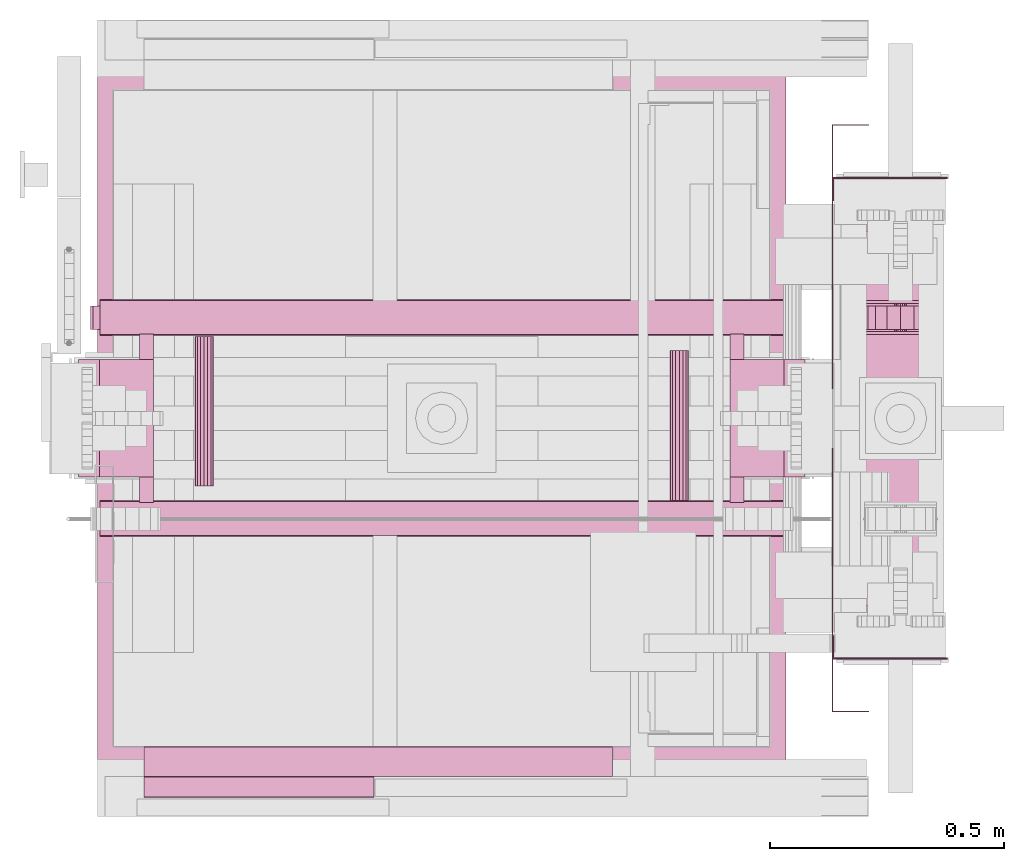
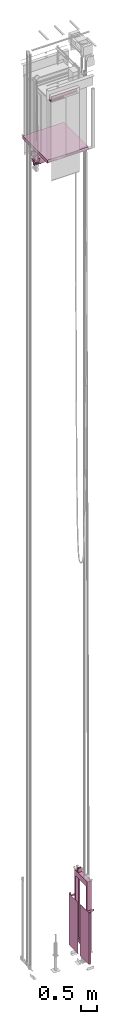
# One storey, part 5 of 13: 6 transport elements.
"""IFC4 building model written with IfcOpenShell, lengths in millimetres."""

import ifcopenshell
import ifcopenshell.guid

model = None  # the IFC model being written
_history = None  # IfcOwnerHistory: only IFC2X3 demands one
_inside = {}  # id of a spatial element -> (the spatial element, [elements in it])
_under = {}  # id of a project, library or spatial element -> (it, [spatial elements below it])
_declared = {}  # id of a project -> (the project, [libraries it declares])
_typed = {}  # id of a type object -> (the type object, [elements of that type])
_made_of = {}  # id of a material, layer set ... -> (it, [elements and type objects made of it])


def new_model(schema):
    """Start an empty IFC model of exactly this schema.

    Asked for "IFC4X3", IfcOpenShell would pick the latest addendum, in which some entities
    have other attributes; the version numbers below select the first issue.
    IFC2X3 requires an IfcOwnerHistory on every rooted entity: one is made here for all.
    """
    global model, _history
    if schema == "IFC4X3":
        model = ifcopenshell.file(schema_version=(4, 3, 0, 0))
    else:
        model = ifcopenshell.file(schema=schema)
    _inside.clear()
    _under.clear()
    _declared.clear()
    _typed.clear()
    _made_of.clear()
    _history = None
    if model.schema == "IFC2X3":
        org = make("IfcOrganization", Name="unknown")
        user = make(
            "IfcPersonAndOrganization",
            ThePerson=make("IfcPerson", FamilyName="unknown"),
            TheOrganization=org,
        )
        app = make(
            "IfcApplication",
            ApplicationDeveloper=org,
            Version="unknown",
            ApplicationFullName="unknown",
            ApplicationIdentifier="unknown",
        )
        _history = make(
            "IfcOwnerHistory",
            OwningUser=user,
            OwningApplication=app,
            ChangeAction="ADDED",
            CreationDate=0,
        )
    return model


def make(cls, **values):
    """One entity of the class cls with the attributes given. An attribute that is None is left unset."""
    return model.create_entity(
        cls, **{name: value for name, value in values.items() if value is not None}
    )


def entity(cls, *values):
    """Any entity or typed value of the class cls, its attributes in the order of the schema. None: left unset."""
    e = model.create_entity(cls)
    for i, value in enumerate(values):
        if value is not None:
            e[i] = value
    return e


def rooted(cls, **values):
    """An entity with a GlobalId (a new one), such as an element, a storey or a relation."""
    return make(cls, GlobalId=ifcopenshell.guid.new(), OwnerHistory=_history, **values)


def si_unit(unit_type, name, prefix=None):
    """IfcSIUnit, for example si_unit("LENGTHUNIT", "METRE", prefix="MILLI")."""
    return make("IfcSIUnit", UnitType=unit_type, Prefix=prefix, Name=name)


def converted_unit(unit_type, name, factor, base, dimensions=None, offset=None):
    """IfcConversionBasedUnit, such as the inch: factor (a typed value) times the base unit."""
    return make(
        "IfcConversionBasedUnit"
        if offset is None
        else "IfcConversionBasedUnitWithOffset",
        ConversionOffset=offset,
        Dimensions=None
        if dimensions is None
        else entity("IfcDimensionalExponents", *dimensions),
        UnitType=unit_type,
        Name=name,
        ConversionFactor=make(
            "IfcMeasureWithUnit", ValueComponent=factor, UnitComponent=base
        ),
    )


def assignment(units):
    """IfcUnitAssignment: the units of a project."""
    return None if units is None else make("IfcUnitAssignment", Units=units)


def point(xyz):
    """IfcCartesianPoint."""
    return None if xyz is None else make("IfcCartesianPoint", Coordinates=xyz)


def direction(xyz):
    """IfcDirection."""
    return None if xyz is None else make("IfcDirection", DirectionRatios=xyz)


def frame(location, z_axis=None, x_axis=None):
    """IfcAxis2Placement3D, a coordinate frame: its origin and axes. An axis left out is left unset."""
    return make(
        "IfcAxis2Placement3D",
        Location=point(location),
        Axis=direction(z_axis),
        RefDirection=direction(x_axis),
    )


def origin_with_axes():
    """The frame at (0, 0, 0) with the z axis (0, 0, 1) and the x axis (1, 0, 0) written out."""
    return frame((0.0, 0.0, 0.0), z_axis=(0.0, 0.0, 1.0), x_axis=(1.0, 0.0, 0.0))


def place(relative_to, where):
    """IfcLocalPlacement: puts the frame where relative to a parent placement (None: the world)."""
    return make(
        "IfcLocalPlacement", PlacementRelTo=relative_to, RelativePlacement=where
    )


def context(
    kind, dimensions, precision=None, world=None, true_north=None, identifier=None
):
    """IfcGeometricRepresentationContext, for example the 3D "Model" context."""
    return make(
        "IfcGeometricRepresentationContext",
        ContextIdentifier=identifier,
        ContextType=kind,
        CoordinateSpaceDimension=dimensions,
        Precision=precision,
        WorldCoordinateSystem=world,
        TrueNorth=true_north,
    )


def subcontext(parent, identifier, kind, view, scale=None):
    """IfcGeometricRepresentationSubContext, for example "Body" below "Model"."""
    return make(
        "IfcGeometricRepresentationSubContext",
        ContextIdentifier=identifier,
        ContextType=kind,
        ParentContext=parent,
        TargetScale=scale,
        TargetView=view,
    )


def project(units=None, contexts=None):
    """IfcProject with its units and contexts."""
    return rooted(
        "IfcProject",
        Name="project",
        RepresentationContexts=contexts,
        UnitsInContext=assignment(units),
    )


def spatial(cls, under=None, at=None, **own):
    """A site, building, storey or space (cls), placed at a placement, below another one or the project."""
    s = rooted(cls, ObjectPlacement=at, **own)
    if under is not None:
        _under.setdefault(under.id(), (under, []))[1].append(s)
    return s


def faces_of(points, faces, orient=None, outer=None):
    """IfcFace entities. A face is a list of loops; a loop is a list of indices into points, from 0.

    orient and outer hold one flag for each loop. By default every Orientation is true, the
    first loop of a face is its IfcFaceOuterBound and the others are IfcFaceBound.
    """
    made = []
    for i, loops in enumerate(faces):
        bounds = []
        for j, loop in enumerate(loops):
            is_outer = j == 0 if outer is None else outer[i][j]
            bounds.append(
                make(
                    "IfcFaceOuterBound" if is_outer else "IfcFaceBound",
                    Bound=make("IfcPolyLoop", Polygon=[points[k] for k in loop]),
                    Orientation=True if orient is None else orient[i][j],
                )
            )
        made.append(make("IfcFace", Bounds=bounds))
    return made


def faceted_brep(points, faces, orient=None, outer=None, voids=None):
    """IfcFacetedBrep: a solid bounded by flat faces; with voids (closed shells), ...WithVoids."""
    shared = [point(p) for p in points]
    hull = make("IfcClosedShell", CfsFaces=faces_of(shared, faces, orient, outer))
    if voids is None:
        return make("IfcFacetedBrep", Outer=hull)
    return make(
        "IfcFacetedBrepWithVoids",
        Outer=hull,
        Voids=[
            make(cls, CfsFaces=faces_of(shared, fs, o, b)) for cls, fs, o, b in voids
        ],
    )


def shape(context_of_items, identifier, shape_type, items):
    """IfcShapeRepresentation: the items that make up one representation, for example the "Body"."""
    return make(
        "IfcShapeRepresentation",
        ContextOfItems=context_of_items,
        RepresentationIdentifier=identifier,
        RepresentationType=shape_type,
        Items=items,
    )


def made_of(thing, what):
    """Note that an element or type object is made of a material, layer set ...; save() writes the relation."""
    if what is not None:
        _made_of.setdefault(what.id(), (what, []))[1].append(thing)
    return thing


def element(
    cls,
    number,
    at=None,
    inside=None,
    cuts=None,
    type_object=None,
    material=None,
    context=None,
    identifier="Body",
    shape_type=None,
    held_by="IfcProductDefinitionShape",
    body=None,
    shapes=None,
    **own,
):
    """One element of the class cls, such as IfcWall. Its Tag is "e" and its number.

    at: its placement. inside: the storey or other place that contains it. cuts: it is an
    opening in that element (IfcRelVoidsElement). A single representation is given by context,
    identifier, shape_type and body (its items); several are given by shapes. held_by: the class
    of the entity that holds the representations. save() writes the other relations.
    """
    e = rooted(cls, Tag="e%d" % number, ObjectPlacement=at, **own)
    if body is not None:
        shapes = [shape(context, identifier, shape_type, body)]
    if shapes is not None:
        e.Representation = make(held_by, Representations=shapes)
    if inside is not None:
        _inside.setdefault(inside.id(), (inside, []))[1].append(e)
    if cuts is not None:
        rooted(
            "IfcRelVoidsElement", RelatingBuildingElement=cuts, RelatedOpeningElement=e
        )
    if type_object is not None:
        _typed.setdefault(type_object.id(), (type_object, []))[1].append(e)
    return made_of(e, material)


def aggregate(whole, parts):
    """IfcRelAggregates: a whole, such as a stair, and the parts it consists of."""
    return rooted("IfcRelAggregates", RelatingObject=whole, RelatedObjects=parts)


def save(model, path):
    """Write the relations noted so far, then the file.

    IfcRelAggregates (storeys below a building ...), IfcRelContainedInSpatialStructure (elements
    in a storey), IfcRelDefinesByType, IfcRelAssociatesMaterial and IfcRelDeclares: one each for
    every whole, place, type object, material and project.
    """
    for whole, parts in _under.values():
        aggregate(whole, parts)
    for where, things in _inside.values():
        rooted(
            "IfcRelContainedInSpatialStructure",
            RelatedElements=things,
            RelatingStructure=where,
        )
    for kind, things in _typed.values():
        rooted("IfcRelDefinesByType", RelatedObjects=things, RelatingType=kind)
    for what, things in _made_of.values():
        rooted("IfcRelAssociatesMaterial", RelatedObjects=things, RelatingMaterial=what)
    for by, libraries in _declared.values():
        rooted("IfcRelDeclares", RelatingContext=by, RelatedDefinitions=libraries)
    model.write(path)


model = new_model("IFC4")

# Units and contexts
context_of_model = context(None, 3, precision=0.01, world=origin_with_axes())
sub_context_1 = subcontext(context_of_model, None, None, "MODEL_VIEW")
sub_context_2 = subcontext(context_of_model, None, None, "MODEL_VIEW")
sub_context_3 = subcontext(context_of_model, None, None, "MODEL_VIEW")
sub_context_4 = subcontext(context_of_model, None, None, "MODEL_VIEW")
sub_context_5 = subcontext(context_of_model, None, None, "MODEL_VIEW")
sub_context_6 = subcontext(context_of_model, None, None, "MODEL_VIEW")
ifc_project = project(units=[converted_unit("PLANEANGLEUNIT", "degree", entity("IfcPlaneAngleMeasure", 0.017453292519943), si_unit("PLANEANGLEUNIT", "RADIAN"), dimensions=[0, 0, 0, 0, 0, 0, 0]), si_unit("LENGTHUNIT", "METRE", prefix="MILLI"), si_unit("MASSUNIT", "GRAM", prefix="KILO"), converted_unit("TIMEUNIT", "year", entity("IfcTimeMeasure", 31557600.0), si_unit("TIMEUNIT", "SECOND"), dimensions=[0, 0, 1, 0, 0, 0, 0]), si_unit("THERMODYNAMICTEMPERATUREUNIT", "DEGREE_CELSIUS"), si_unit("AREAUNIT", "SQUARE_METRE"), si_unit("FORCEUNIT", "NEWTON"), si_unit("VOLUMEUNIT", "CUBIC_METRE"), si_unit("PRESSUREUNIT", "PASCAL"), si_unit("SOLIDANGLEUNIT", "STERADIAN")], contexts=[context_of_model])

# Site, building, storey
site = spatial("IfcSite", under=ifc_project)
building = spatial("IfcBuilding", under=site, Name="Document")
placement = place(None, origin_with_axes())
storey_placement = place(placement, frame((0.0, 0.0, -26400.0), z_axis=(0.0, 0.0, 1.0), x_axis=(1.0, 0.0, 0.0)))
storey = spatial("IfcBuildingStorey", under=building, at=storey_placement, Name="Z -26400", Elevation=-26400.0)

# Transport elements
transport_element_1_placement = place(storey_placement, frame((1734.0, 1025.0, 0.0), z_axis=(0.0, 0.0, 1.0), x_axis=(0.0, 1.0, 0.0)))
element("IfcTransportElement", 1, at=transport_element_1_placement, inside=storey, ObjectType="GGM3 Screen CMG", PredefinedType="ELEVATOR", context=sub_context_1, shape_type="Brep", body=[
    faceted_brep([(-626.0, 1.0, 2245.0), (-63.5, 1.0, 2245.0), (-63.5, 1.0, 300.0), (-626.0, 1.0, 300.0), (-63.5, 0.0, 300.0), (-63.5, 0.0, 2245.0), (-625.0, 0.0, 2245.0), (-625.0, 0.0, 300.0), (-625.0, -77.0, 300.0), (-625.0, -77.0, 2245.0), (-626.0, -77.0, 2245.0), (-626.0, -77.0, 300.0)], [[[0, 1, 2, 3]], [[4, 5, 6, 7]], [[8, 9, 10, 11]], [[11, 10, 0, 3]], [[6, 9, 8, 7]], [[1, 5, 4, 2]], [[3, 2, 4, 7, 8, 11]], [[10, 9, 6, 5, 1, 0]]]),
    faceted_brep([(63.5, 1.0, 2245.0), (626.0, 1.0, 2245.0), (626.0, 1.0, 300.0), (63.5, 1.0, 300.0), (625.0, 0.0, 300.0), (625.0, 0.0, 2245.0), (63.5, 0.0, 2245.0), (63.5, 0.0, 300.0), (626.0, -77.0, 300.0), (626.0, -77.0, 2245.0), (625.0, -77.0, 2245.0), (625.0, -77.0, 300.0)], [[[0, 1, 2, 3]], [[4, 5, 6, 7]], [[8, 9, 10, 11]], [[7, 6, 0, 3]], [[1, 9, 8, 2]], [[11, 10, 5, 4]], [[2, 8, 11, 4, 7, 3]], [[6, 5, 10, 9, 1, 0]]]),
    faceted_brep([(464.0, 0.0, 2245.0), (514.0, 0.0, 2245.0), (514.0, 0.0, 2170.0), (464.0, 0.0, 2170.0), (511.0, -3.0, 2170.0), (511.0, -3.0, 2245.0), (464.0, -3.0, 2245.0), (464.0, -3.0, 2170.0), (514.0, -245.0, 2170.0), (514.0, -245.0, 2245.0), (511.0, -245.0, 2245.0), (511.0, -245.0, 2170.0)], [[[0, 1, 2, 3]], [[4, 5, 6, 7]], [[8, 9, 10, 11]], [[7, 6, 0, 3]], [[1, 9, 8, 2]], [[11, 10, 5, 4]], [[2, 8, 11, 4, 7, 3]], [[6, 5, 10, 9, 1, 0]]]),
    faceted_brep([(-514.0, 0.0, 2245.0), (-464.0, 0.0, 2245.0), (-464.0, 0.0, 2170.0), (-514.0, 0.0, 2170.0), (-464.0, -3.0, 2170.0), (-464.0, -3.0, 2245.0), (-511.0, -3.0, 2245.0), (-511.0, -3.0, 2170.0), (-511.0, -245.0, 2170.0), (-511.0, -245.0, 2245.0), (-514.0, -245.0, 2245.0), (-514.0, -245.0, 2170.0)], [[[0, 1, 2, 3]], [[4, 5, 6, 7]], [[8, 9, 10, 11]], [[11, 10, 0, 3]], [[6, 9, 8, 7]], [[1, 5, 4, 2]], [[3, 2, 4, 7, 8, 11]], [[10, 9, 6, 5, 1, 0]]]),
])
transport_element_2_placement = place(storey_placement, frame((1879.0, 1025.0, 489.0), z_axis=(0.0, 0.0, 1.0), x_axis=(0.0, 1.0, 0.0)))
element("IfcTransportElement", 2, at=transport_element_2_placement, inside=storey, ObjectType="S5500 GGM3 right/rear", PredefinedType="ELEVATOR", context=sub_context_2, shape_type="Brep", body=[
    faceted_brep([(245.0, 12.5, 2840.0), (245.0, 11.5484619140625, 2844.783447265625), (245.0, 8.8388671875, 2848.8388671875), (245.0, 4.7835693359375, 2851.548583984375), (245.0, 0.0, 2852.5), (245.0, -4.7835693359375, 2851.548583984375), (245.0, -8.8388671875, 2848.8388671875), (245.0, -11.5484619140625, 2844.783447265625), (245.0, -12.5, 2840.0), (245.0, -11.5484619140625, 2835.216552734375), (245.0, -8.8388671875, 2831.1611328125), (245.0, -4.7835693359375, 2828.451416015625), (245.0, 0.0, 2827.5), (245.0, 4.7835693359375, 2828.451416015625), (245.0, 8.8388671875, 2831.1611328125), (245.0, 11.5484619140625, 2835.216552734375), (185.0, 12.5, 2840.0), (185.0, 11.5484619140625, 2835.216552734375), (185.0, 8.8388671875, 2831.1611328125), (185.0, 4.7835693359375, 2828.451416015625), (185.0, 0.0, 2827.5), (185.0, -4.7835693359375, 2828.451416015625), (185.0, -8.8388671875, 2831.1611328125), (185.0, -11.5484619140625, 2835.216552734375), (185.0, -12.5, 2840.0), (185.0, -11.5484619140625, 2844.783447265625), (185.0, -8.8388671875, 2848.8388671875), (185.0, -4.7835693359375, 2851.548583984375), (185.0, 0.0, 2852.5), (185.0, 4.7835693359375, 2851.548583984375), (185.0, 8.8388671875, 2848.8388671875), (185.0, 11.5484619140625, 2844.783447265625)], [[[0, 1, 2, 3, 4, 5, 6, 7, 8, 9, 10, 11, 12, 13, 14, 15]], [[16, 17, 18, 19, 20, 21, 22, 23, 24, 25, 26, 27, 28, 29, 30, 31]], [[0, 15, 17, 16]], [[15, 14, 18, 17]], [[14, 13, 19, 18]], [[13, 12, 20, 19]], [[12, 11, 21, 20]], [[11, 10, 22, 21]], [[10, 9, 23, 22]], [[9, 8, 24, 23]], [[8, 7, 25, 24]], [[7, 6, 26, 25]], [[6, 5, 27, 26]], [[5, 4, 28, 27]], [[4, 3, 29, 28]], [[3, 2, 30, 29]], [[2, 1, 31, 30]], [[1, 0, 16, 31]]]),
    faceted_brep([(179.0, 77.0, 2760.0), (179.0, 77.0, 2910.0), (185.0, 77.0, 2910.0), (185.0, 77.0, 2766.0), (245.0, 77.0, 2766.0), (245.0, 77.0, 2910.0), (251.0, 77.0, 2910.0), (251.0, 77.0, 2760.0), (251.0, -77.0, 2760.0), (251.0, -77.0, 2910.0), (245.0, -77.0, 2910.0), (245.0, -77.0, 2766.0), (185.0, -77.0, 2766.0), (185.0, -77.0, 2910.0), (179.0, -77.0, 2910.0), (179.0, -77.0, 2760.0)], [[[0, 1, 2, 3, 4, 5, 6, 7]], [[8, 9, 10, 11, 12, 13, 14, 15]], [[15, 14, 1, 0]], [[2, 13, 12, 3]], [[11, 10, 5, 4]], [[6, 9, 8, 7]], [[7, 8, 15, 0]], [[12, 11, 4, 3]], [[14, 13, 2, 1]], [[10, 9, 6, 5]]]),
    faceted_brep([(-400.0, 80.0, 2760.0), (-330.0, 80.0, 2760.0), (-330.0, 80.0, 160.0), (-400.0, 80.0, 160.0), (-330.0, 77.0, 160.0), (-330.0, 77.0, 2760.0), (-397.0, 77.0, 2760.0), (-397.0, 77.0, 160.0), (-397.0, -77.0, 2760.0), (-330.0, -77.0, 2760.0), (-330.0, -77.0, 160.0), (-397.0, -77.0, 160.0), (-330.0, -80.0, 160.0), (-330.0, -80.0, 2760.0), (-400.0, -80.0, 2760.0), (-400.0, -80.0, 160.0)], [[[0, 1, 2, 3]], [[4, 5, 6, 7]], [[8, 9, 10, 11]], [[12, 13, 14, 15]], [[15, 14, 0, 3]], [[6, 8, 11, 7]], [[1, 5, 4, 2]], [[9, 13, 12, 10]], [[2, 4, 7, 11, 10, 12, 15, 3]], [[0, 14, 13, 9, 8, 6, 5, 1]]]),
    faceted_brep([(240.0, 75.0, 2840.0), (240.0, 69.291015625, 2868.701171875), (240.0, 53.032958984375, 2893.032958984375), (240.0, 28.7012939453125, 2909.291015625), (240.0, 0.0, 2915.0), (240.0, -28.7012939453125, 2909.291015625), (240.0, -53.032958984375, 2893.032958984375), (240.0, -69.291015625, 2868.701171875), (240.0, -75.0, 2840.0), (240.0, -69.291015625, 2811.298828125), (240.0, -53.032958984375, 2786.967041015625), (240.0, -28.7012939453125, 2770.708984375), (240.0, 0.0, 2765.0), (240.0, 28.7012939453125, 2770.708984375), (240.0, 53.032958984375, 2786.967041015625), (240.0, 69.291015625, 2811.298828125), (190.0, 75.0, 2840.0), (190.0, 69.291015625, 2811.298828125), (190.0, 53.032958984375, 2786.967041015625), (190.0, 28.7012939453125, 2770.708984375), (190.0, 0.0, 2765.0), (190.0, -28.7012939453125, 2770.708984375), (190.0, -53.032958984375, 2786.967041015625), (190.0, -69.291015625, 2811.298828125), (190.0, -75.0, 2840.0), (190.0, -69.291015625, 2868.701171875), (190.0, -53.032958984375, 2893.032958984375), (190.0, -28.7012939453125, 2909.291015625), (190.0, 0.0, 2915.0), (190.0, 28.7012939453125, 2909.291015625), (190.0, 53.032958984375, 2893.032958984375), (190.0, 69.291015625, 2868.701171875)], [[[0, 1, 2, 3, 4, 5, 6, 7, 8, 9, 10, 11, 12, 13, 14, 15]], [[16, 17, 18, 19, 20, 21, 22, 23, 24, 25, 26, 27, 28, 29, 30, 31]], [[0, 15, 17, 16]], [[15, 14, 18, 17]], [[14, 13, 19, 18]], [[13, 12, 20, 19]], [[12, 11, 21, 20]], [[11, 10, 22, 21]], [[10, 9, 23, 22]], [[9, 8, 24, 23]], [[8, 7, 25, 24]], [[7, 6, 26, 25]], [[6, 5, 27, 26]], [[5, 4, 28, 27]], [[4, 3, 29, 28]], [[3, 2, 30, 29]], [[2, 1, 31, 30]], [[1, 0, 16, 31]]]),
    faceted_brep([(-70.0, 70.0, 150.0), (-70.0, 70.0, 0.0), (-70.0, -70.0, 0.0), (-70.0, -70.0, 150.0), (70.0, 70.0, 150.0), (70.0, -70.0, 150.0), (70.0, -70.0, 0.0), (70.0, 70.0, 0.0)], [[[0, 1, 2, 3]], [[4, 5, 6, 7]], [[0, 3, 5, 4]], [[3, 2, 6, 5]], [[2, 1, 7, 6]], [[1, 0, 4, 7]]]),
    faceted_brep([(-397.0, 77.0, 2760.0), (397.0, 77.0, 2760.0), (397.0, 77.0, 2560.0), (-397.0, 77.0, 2560.0), (397.0, 71.0, 2560.0), (397.0, 71.0, 2754.0), (-397.0, 71.0, 2754.0), (-397.0, 71.0, 2560.0), (-397.0, -71.0, 2754.0), (397.0, -71.0, 2754.0), (397.0, -71.0, 2560.0), (-397.0, -71.0, 2560.0), (397.0, -77.0, 2560.0), (397.0, -77.0, 2760.0), (-397.0, -77.0, 2760.0), (-397.0, -77.0, 2560.0)], [[[0, 1, 2, 3]], [[4, 5, 6, 7]], [[8, 9, 10, 11]], [[12, 13, 14, 15]], [[7, 6, 8, 11, 15, 14, 0, 3]], [[1, 13, 12, 10, 9, 5, 4, 2]], [[2, 4, 7, 3]], [[14, 13, 1, 0]], [[5, 9, 8, 6]], [[10, 12, 15, 11]]]),
    faceted_brep([(-397.0, 77.0, 310.0), (397.0, 77.0, 310.0), (397.0, 77.0, 160.0), (-397.0, 77.0, 160.0), (397.0, 71.0, 166.0), (397.0, 71.0, 310.0), (-397.0, 71.0, 310.0), (-397.0, 71.0, 166.0), (-397.0, -71.0, 310.0), (397.0, -71.0, 310.0), (397.0, -71.0, 166.0), (-397.0, -71.0, 166.0), (397.0, -77.0, 160.0), (397.0, -77.0, 310.0), (-397.0, -77.0, 310.0), (-397.0, -77.0, 160.0)], [[[0, 1, 2, 3]], [[4, 5, 6, 7]], [[8, 9, 10, 11]], [[12, 13, 14, 15]], [[3, 15, 14, 8, 11, 7, 6, 0]], [[1, 5, 4, 10, 9, 13, 12, 2]], [[2, 12, 15, 3]], [[11, 10, 4, 7]], [[6, 5, 1, 0]], [[14, 13, 9, 8]]]),
    faceted_brep([(330.0, 80.0, 2760.0), (400.0, 80.0, 2760.0), (400.0, 80.0, 160.0), (330.0, 80.0, 160.0), (397.0, 77.0, 160.0), (397.0, 77.0, 2760.0), (330.0, 77.0, 2760.0), (330.0, 77.0, 160.0), (330.0, -77.0, 2760.0), (397.0, -77.0, 2760.0), (397.0, -77.0, 160.0), (330.0, -77.0, 160.0), (400.0, -80.0, 160.0), (400.0, -80.0, 2760.0), (330.0, -80.0, 2760.0), (330.0, -80.0, 160.0)], [[[0, 1, 2, 3]], [[4, 5, 6, 7]], [[8, 9, 10, 11]], [[12, 13, 14, 15]], [[7, 6, 0, 3]], [[1, 13, 12, 2]], [[10, 9, 5, 4]], [[15, 14, 8, 11]], [[2, 12, 15, 11, 10, 4, 7, 3]], [[6, 5, 9, 8, 14, 13, 1, 0]]]),
    faceted_brep([(-75.0, 80.0, 160.0), (-75.0, 80.0, 150.0), (-75.0, -80.0, 150.0), (-75.0, -80.0, 160.0), (75.0, 80.0, 160.0), (75.0, -80.0, 160.0), (75.0, -80.0, 150.0), (75.0, 80.0, 150.0)], [[[0, 1, 2, 3]], [[4, 5, 6, 7]], [[0, 3, 5, 4]], [[3, 2, 6, 5]], [[2, 1, 7, 6]], [[1, 0, 4, 7]]]),
])
transport_element_3_placement = place(storey_placement, frame((900.0, 1025.0, 30795.0), z_axis=(0.0, 0.0, 1.0), x_axis=(-1.0, 0.0, 0.0)))
element("IfcTransportElement", 3, at=transport_element_3_placement, inside=storey, ObjectType="Car Safety", PredefinedType="ELEVATOR", context=sub_context_3, shape_type="Brep", body=[
    faceted_brep([(775.0, 125.0, -20.0), (775.0, 30.0, -20.0), (775.0, 30.0, -58.5), (775.0, 125.0, -58.5), (775.0, -30.0, -20.0), (775.0, -125.0, -20.0), (775.0, -125.0, -58.5), (775.0, -30.0, -58.5), (730.0, 30.0, -20.0), (730.0, -30.0, -20.0), (730.0, -30.0, -58.5), (730.0, 30.0, -58.5), (615.0, -125.0, -58.5), (615.0, -125.0, -20.0), (615.0, 125.0, -20.0), (615.0, 125.0, -58.5)], [[[0, 1, 2, 3]], [[4, 5, 6, 7]], [[8, 9, 10, 11]], [[12, 13, 14, 15]], [[15, 14, 0, 3]], [[1, 8, 11, 2]], [[10, 9, 4, 7]], [[5, 13, 12, 6]], [[2, 11, 10, 7, 6, 12, 15, 3]], [[14, 13, 5, 4, 9, 8, 1, 0]]]),
    faceted_brep([(775.0, 125.0, -98.5), (775.0, 30.0, -98.5), (775.0, 30.0, -125.0), (775.0, 125.0, -125.0), (775.0, -30.0, -98.5), (775.0, -125.0, -98.5), (775.0, -125.0, -125.0), (775.0, -30.0, -125.0), (730.0, 30.0, -98.5), (730.0, -30.0, -98.5), (730.0, -30.0, -125.0), (730.0, 30.0, -125.0), (615.0, -125.0, -125.0), (615.0, -125.0, -98.5), (615.0, 125.0, -98.5), (615.0, 125.0, -125.0)], [[[0, 1, 2, 3]], [[4, 5, 6, 7]], [[8, 9, 10, 11]], [[12, 13, 14, 15]], [[15, 14, 0, 3]], [[1, 8, 11, 2]], [[10, 9, 4, 7]], [[5, 13, 12, 6]], [[2, 11, 10, 7, 6, 12, 15, 3]], [[14, 13, 5, 4, 9, 8, 1, 0]]]),
    faceted_brep([(747.0, 30.0, -215.0), (747.0, 40.0, -215.0), (777.0, 40.0, -215.0), (777.0, 30.0, -215.0), (747.0, 30.0, -125.0), (777.0, 30.0, -125.0), (777.0, 40.0, -125.0), (747.0, 40.0, -125.0)], [[[0, 1, 2, 3]], [[4, 5, 6, 7]], [[0, 3, 5, 4]], [[3, 2, 6, 5]], [[2, 1, 7, 6]], [[1, 0, 4, 7]]]),
    faceted_brep([(-615.0, 125.0, -98.5), (-615.0, -125.0, -98.5), (-615.0, -125.0, -125.0), (-615.0, 125.0, -125.0), (-775.0, 30.0, -125.0), (-775.0, 30.0, -98.5), (-775.0, 125.0, -98.5), (-775.0, 125.0, -125.0), (-730.0, -30.0, -125.0), (-730.0, -30.0, -98.5), (-730.0, 30.0, -98.5), (-730.0, 30.0, -125.0), (-775.0, -125.0, -125.0), (-775.0, -125.0, -98.5), (-775.0, -30.0, -98.5), (-775.0, -30.0, -125.0)], [[[0, 1, 2, 3]], [[4, 5, 6, 7]], [[8, 9, 10, 11]], [[12, 13, 14, 15]], [[7, 6, 0, 3]], [[1, 13, 12, 2]], [[10, 5, 4, 11]], [[15, 14, 9, 8]], [[3, 2, 12, 15, 8, 11, 4, 7]], [[6, 5, 10, 9, 14, 13, 1, 0]]]),
    faceted_brep([(777.0, -10.5, -136.0), (777.0, -18.5, -136.0), (777.0, -18.5, -211.0), (777.0, -10.5, -211.0), (774.0, -18.5, -136.0), (774.0, -30.0, -136.0), (774.0, -30.0, -211.0), (774.0, -18.5, -211.0), (751.0, -18.5, -211.0), (751.0, -18.5, -136.0), (751.0, -10.5, -136.0), (751.0, -10.5, -211.0), (754.0, -30.0, -211.0), (754.0, -30.0, -136.0), (754.0, -18.5, -136.0), (754.0, -18.5, -211.0)], [[[0, 1, 2, 3]], [[4, 5, 6, 7]], [[8, 9, 10, 11]], [[12, 13, 14, 15]], [[11, 10, 0, 3]], [[1, 4, 7, 2]], [[5, 13, 12, 6]], [[14, 9, 8, 15]], [[2, 7, 6, 12, 15, 8, 11, 3]], [[10, 9, 14, 13, 5, 4, 1, 0]]]),
    faceted_brep([(-615.0, -180.0, -104.0), (-645.0, -180.0, -104.0), (-645.0, -125.0, -104.0), (-615.0, -125.0, -104.0), (-615.0, -180.0, -42.0), (-615.0, -125.0, -42.0), (-645.0, -125.0, -42.0), (-645.0, -180.0, -42.0)], [[[0, 1, 2, 3]], [[4, 5, 6, 7]], [[0, 3, 5, 4]], [[3, 2, 6, 5]], [[2, 1, 7, 6]], [[1, 0, 4, 7]]]),
    faceted_brep([(-615.0, 125.0, -104.0), (-645.0, 125.0, -104.0), (-645.0, 180.0, -104.0), (-615.0, 180.0, -104.0), (-615.0, 125.0, -42.0), (-615.0, 180.0, -42.0), (-645.0, 180.0, -42.0), (-645.0, 125.0, -42.0)], [[[0, 1, 2, 3]], [[4, 5, 6, 7]], [[0, 3, 5, 4]], [[3, 2, 6, 5]], [[2, 1, 7, 6]], [[1, 0, 4, 7]]]),
    faceted_brep([(-507.0, 175.0, -108.5), (-514.6536865234375, 175.0, -106.978515625), (-521.14208984375, 175.0, -102.642578125), (-525.4775390625, 175.0, -96.154296875), (-527.0, 175.0, -88.5), (-525.4775390625, 175.0, -80.845703125), (-521.14208984375, 175.0, -74.357421875), (-514.6536865234375, 175.0, -70.021484375), (-507.0, 175.0, -68.5), (-499.3463134765625, 175.0, -70.021484375), (-492.85791015625, 175.0, -74.357421875), (-488.5224609375, 175.0, -80.845703125), (-487.0, 175.0, -88.5), (-488.5224609375, 175.0, -96.154296875), (-492.85791015625, 175.0, -102.642578125), (-499.3463134765625, 175.0, -106.978515625), (-507.0, -145.0, -108.5), (-499.3463134765625, -145.0, -106.978515625), (-492.85791015625, -145.0, -102.642578125), (-488.5224609375, -145.0, -96.154296875), (-487.0, -145.0, -88.5), (-488.5224609375, -145.0, -80.845703125), (-492.85791015625, -145.0, -74.357421875), (-499.3463134765625, -145.0, -70.021484375), (-507.0, -145.0, -68.5), (-514.6536865234375, -145.0, -70.021484375), (-521.14208984375, -145.0, -74.357421875), (-525.4775390625, -145.0, -80.845703125), (-527.0, -145.0, -88.5), (-525.4775390625, -145.0, -96.154296875), (-521.14208984375, -145.0, -102.642578125), (-514.6536865234375, -145.0, -106.978515625)], [[[0, 1, 2, 3, 4, 5, 6, 7, 8, 9, 10, 11, 12, 13, 14, 15]], [[16, 17, 18, 19, 20, 21, 22, 23, 24, 25, 26, 27, 28, 29, 30, 31]], [[0, 15, 17, 16]], [[15, 14, 18, 17]], [[14, 13, 19, 18]], [[13, 12, 20, 19]], [[12, 11, 21, 20]], [[11, 10, 22, 21]], [[10, 9, 23, 22]], [[9, 8, 24, 23]], [[8, 7, 25, 24]], [[7, 6, 26, 25]], [[6, 5, 27, 26]], [[5, 4, 28, 27]], [[4, 3, 29, 28]], [[3, 2, 30, 29]], [[2, 1, 31, 30]], [[1, 0, 16, 31]]]),
    faceted_brep([(-777.0, -30.0, -125.0), (-777.0, -40.0, -125.0), (-747.0, -40.0, -125.0), (-747.0, -30.0, -125.0), (-777.0, -30.0, -215.0), (-747.0, -30.0, -215.0), (-747.0, -40.0, -215.0), (-777.0, -40.0, -215.0)], [[[0, 1, 2, 3]], [[4, 5, 6, 7]], [[0, 3, 5, 4]], [[3, 2, 6, 5]], [[2, 1, 7, 6]], [[1, 0, 4, 7]]]),
    faceted_brep([(615.0, 180.0, -104.0), (645.0, 180.0, -104.0), (645.0, 125.0, -104.0), (615.0, 125.0, -104.0), (615.0, 180.0, -42.0), (615.0, 125.0, -42.0), (645.0, 125.0, -42.0), (645.0, 180.0, -42.0)], [[[0, 1, 2, 3]], [[4, 5, 6, 7]], [[0, 3, 5, 4]], [[3, 2, 6, 5]], [[2, 1, 7, 6]], [[1, 0, 4, 7]]]),
    faceted_brep([(615.0, -125.0, -104.0), (645.0, -125.0, -104.0), (645.0, -180.0, -104.0), (615.0, -180.0, -104.0), (615.0, -125.0, -42.0), (615.0, -180.0, -42.0), (645.0, -180.0, -42.0), (645.0, -125.0, -42.0)], [[[0, 1, 2, 3]], [[4, 5, 6, 7]], [[0, 3, 5, 4]], [[3, 2, 6, 5]], [[2, 1, 7, 6]], [[1, 0, 4, 7]]]),
    faceted_brep([(507.0, 145.0, -108.5), (499.3463439941406, 145.0, -106.978515625), (492.85784912109375, 145.0, -102.642578125), (488.52239990234375, 145.0, -96.154296875), (487.0, 145.0, -88.5), (488.52239990234375, 145.0, -80.845703125), (492.85784912109375, 145.0, -74.357421875), (499.3463439941406, 145.0, -70.021484375), (507.0, 145.0, -68.5), (514.6536560058594, 145.0, -70.021484375), (521.1421508789062, 145.0, -74.357421875), (525.4776000976562, 145.0, -80.845703125), (527.0, 145.0, -88.5), (525.4776000976562, 145.0, -96.154296875), (521.1421508789062, 145.0, -102.642578125), (514.6536560058594, 145.0, -106.978515625), (507.0, -175.0, -108.5), (514.6536560058594, -175.0, -106.978515625), (521.1421508789062, -175.0, -102.642578125), (525.4776000976562, -175.0, -96.154296875), (527.0, -175.0, -88.5), (525.4776000976562, -175.0, -80.845703125), (521.1421508789062, -175.0, -74.357421875), (514.6536560058594, -175.0, -70.021484375), (507.0, -175.0, -68.5), (499.3463439941406, -175.0, -70.021484375), (492.85784912109375, -175.0, -74.357421875), (488.52239990234375, -175.0, -80.845703125), (487.0, -175.0, -88.5), (488.52239990234375, -175.0, -96.154296875), (492.85784912109375, -175.0, -102.642578125), (499.3463439941406, -175.0, -106.978515625)], [[[0, 1, 2, 3, 4, 5, 6, 7, 8, 9, 10, 11, 12, 13, 14, 15]], [[16, 17, 18, 19, 20, 21, 22, 23, 24, 25, 26, 27, 28, 29, 30, 31]], [[0, 15, 17, 16]], [[15, 14, 18, 17]], [[14, 13, 19, 18]], [[13, 12, 20, 19]], [[12, 11, 21, 20]], [[11, 10, 22, 21]], [[10, 9, 23, 22]], [[9, 8, 24, 23]], [[8, 7, 25, 24]], [[7, 6, 26, 25]], [[6, 5, 27, 26]], [[5, 4, 28, 27]], [[4, 3, 29, 28]], [[3, 2, 30, 29]], [[2, 1, 31, 30]], [[1, 0, 16, 31]]]),
    faceted_brep([(747.0, -40.0, -215.0), (747.0, -30.0, -215.0), (777.0, -30.0, -215.0), (777.0, -40.0, -215.0), (747.0, -40.0, -125.0), (777.0, -40.0, -125.0), (777.0, -30.0, -125.0), (747.0, -30.0, -125.0)], [[[0, 1, 2, 3]], [[4, 5, 6, 7]], [[0, 3, 5, 4]], [[3, 2, 6, 5]], [[2, 1, 7, 6]], [[1, 0, 4, 7]]]),
    faceted_brep([(774.0, 30.0, -136.0), (774.0, 18.5, -136.0), (774.0, 18.5, -211.0), (774.0, 30.0, -211.0), (777.0, 18.5, -136.0), (777.0, 10.5, -136.0), (777.0, 10.5, -211.0), (777.0, 18.5, -211.0), (754.0, 18.5, -211.0), (754.0, 18.5, -136.0), (754.0, 30.0, -136.0), (754.0, 30.0, -211.0), (751.0, 10.5, -211.0), (751.0, 10.5, -136.0), (751.0, 18.5, -136.0), (751.0, 18.5, -211.0)], [[[0, 1, 2, 3]], [[4, 5, 6, 7]], [[8, 9, 10, 11]], [[12, 13, 14, 15]], [[11, 10, 0, 3]], [[2, 1, 4, 7]], [[5, 13, 12, 6]], [[15, 14, 9, 8]], [[2, 7, 6, 12, 15, 8, 11, 3]], [[10, 9, 14, 13, 5, 4, 1, 0]]]),
    faceted_brep([(-615.0, 125.0, -20.0), (-615.0, -125.0, -20.0), (-615.0, -125.0, -58.5), (-615.0, 125.0, -58.5), (-775.0, 30.0, -58.5), (-775.0, 30.0, -20.0), (-775.0, 125.0, -20.0), (-775.0, 125.0, -58.5), (-730.0, -30.0, -58.5), (-730.0, -30.0, -20.0), (-730.0, 30.0, -20.0), (-730.0, 30.0, -58.5), (-775.0, -125.0, -58.5), (-775.0, -125.0, -20.0), (-775.0, -30.0, -20.0), (-775.0, -30.0, -58.5)], [[[0, 1, 2, 3]], [[4, 5, 6, 7]], [[8, 9, 10, 11]], [[12, 13, 14, 15]], [[7, 6, 0, 3]], [[1, 13, 12, 2]], [[10, 5, 4, 11]], [[15, 14, 9, 8]], [[2, 12, 15, 8, 11, 4, 7, 3]], [[0, 6, 5, 10, 9, 14, 13, 1]]]),
    faceted_brep([(-747.0, 30.0, -125.0), (-747.0, 40.0, -125.0), (-777.0, 40.0, -125.0), (-777.0, 30.0, -125.0), (-747.0, 30.0, -215.0), (-777.0, 30.0, -215.0), (-777.0, 40.0, -215.0), (-747.0, 40.0, -215.0)], [[[0, 1, 2, 3]], [[4, 5, 6, 7]], [[0, 3, 5, 4]], [[3, 2, 6, 5]], [[2, 1, 7, 6]], [[1, 0, 4, 7]]]),
    faceted_brep([(-751.0, -10.5, -136.0), (-751.0, -18.5, -136.0), (-751.0, -18.5, -211.0), (-751.0, -10.5, -211.0), (-754.0, -18.5, -136.0), (-754.0, -30.0, -136.0), (-754.0, -30.0, -211.0), (-754.0, -18.5, -211.0), (-777.0, -18.5, -211.0), (-777.0, -18.5, -136.0), (-777.0, -10.5, -136.0), (-777.0, -10.5, -211.0), (-774.0, -30.0, -211.0), (-774.0, -30.0, -136.0), (-774.0, -18.5, -136.0), (-774.0, -18.5, -211.0)], [[[0, 1, 2, 3]], [[4, 5, 6, 7]], [[8, 9, 10, 11]], [[12, 13, 14, 15]], [[11, 10, 0, 3]], [[1, 4, 7, 2]], [[5, 13, 12, 6]], [[14, 9, 8, 15]], [[2, 7, 6, 12, 15, 8, 11, 3]], [[10, 9, 14, 13, 5, 4, 1, 0]]]),
    faceted_brep([(-754.0, 30.0, -136.0), (-754.0, 18.5, -136.0), (-754.0, 18.5, -211.0), (-754.0, 30.0, -211.0), (-751.0, 18.5, -136.0), (-751.0, 10.5, -136.0), (-751.0, 10.5, -211.0), (-751.0, 18.5, -211.0), (-774.0, 18.5, -211.0), (-774.0, 18.5, -136.0), (-774.0, 30.0, -136.0), (-774.0, 30.0, -211.0), (-777.0, 10.5, -211.0), (-777.0, 10.5, -136.0), (-777.0, 18.5, -136.0), (-777.0, 18.5, -211.0)], [[[0, 1, 2, 3]], [[4, 5, 6, 7]], [[8, 9, 10, 11]], [[12, 13, 14, 15]], [[11, 10, 0, 3]], [[2, 1, 4, 7]], [[5, 13, 12, 6]], [[9, 8, 15, 14]], [[2, 7, 6, 12, 15, 8, 11, 3]], [[10, 9, 14, 13, 5, 4, 1, 0]]]),
    faceted_brep([(730.0, -125.0, -20.0), (615.0, -125.0, -20.0), (615.0, 125.0, -20.0), (730.0, 125.0, -20.0), (730.0, -125.0, 0.0), (730.0, 125.0, 0.0), (615.0, 125.0, 0.0), (615.0, -125.0, 0.0)], [[[0, 1, 2, 3]], [[4, 5, 6, 7]], [[0, 3, 5, 4]], [[3, 2, 6, 5]], [[2, 1, 7, 6]], [[1, 0, 4, 7]]]),
    faceted_brep([(-730.0, -125.0, 0.0), (-615.0, -125.0, 0.0), (-615.0, 125.0, 0.0), (-730.0, 125.0, 0.0), (-730.0, -125.0, -20.0), (-730.0, 125.0, -20.0), (-615.0, 125.0, -20.0), (-615.0, -125.0, -20.0)], [[[0, 1, 2, 3]], [[4, 5, 6, 7]], [[0, 3, 5, 4]], [[3, 2, 6, 5]], [[2, 1, 7, 6]], [[1, 0, 4, 7]]]),
])
transport_element_4_placement = place(storey_placement, frame((900.0, 810.0, 30872.0), z_axis=(0.0, 0.0, 1.0), x_axis=(1.0, 0.0, 0.0)))
element("IfcTransportElement", 4, at=transport_element_4_placement, inside=storey, ObjectType="S5500", PredefinedType="ELEVATOR", context=sub_context_4, shape_type="Brep", body=[
    faceted_brep([(-729.0, 393.5, 105.0), (-729.0, 466.5, 105.0), (-729.0, 466.5, -65.0), (-729.0, 463.5, -65.0), (-729.0, 463.5, 102.0), (-729.0, 396.5, 102.0), (-729.0, 396.5, -65.0), (-729.0, 393.5, -65.0), (729.0, 396.5, -65.0), (729.0, 396.5, 102.0), (729.0, 463.5, 102.0), (729.0, 463.5, -65.0), (729.0, 466.5, -65.0), (729.0, 466.5, 105.0), (729.0, 393.5, 105.0), (729.0, 393.5, -65.0)], [[[0, 1, 2, 3, 4, 5, 6, 7]], [[8, 9, 10, 11, 12, 13, 14, 15]], [[15, 14, 0, 7]], [[5, 9, 8, 6]], [[11, 10, 4, 3]], [[1, 13, 12, 2]], [[6, 8, 15, 7]], [[2, 12, 11, 3]], [[14, 13, 1, 0]], [[4, 10, 9, 5]]]),
    faceted_brep([(-729.0, 391.5, -17.0), (-729.0, 393.5, -17.0), (-729.0, 393.5, -95.0), (-729.0, 466.5, -95.0), (-729.0, 466.5, -17.0), (-729.0, 468.5, -17.0), (-729.0, 468.5, -97.0), (-729.0, 391.5, -97.0), (729.0, 391.5, -97.0), (729.0, 468.5, -97.0), (729.0, 468.5, -17.0), (729.0, 466.5, -17.0), (729.0, 466.5, -95.0), (729.0, 393.5, -95.0), (729.0, 393.5, -17.0), (729.0, 391.5, -17.0)], [[[0, 1, 2, 3, 4, 5, 6, 7]], [[8, 9, 10, 11, 12, 13, 14, 15]], [[8, 15, 0, 7]], [[1, 14, 13, 2]], [[12, 11, 4, 3]], [[5, 10, 9, 6]], [[6, 9, 8, 7]], [[13, 12, 3, 2]], [[15, 14, 1, 0]], [[11, 10, 5, 4]]]),
    faceted_brep([(-729.0, -35.5, 105.0), (-729.0, 37.5, 105.0), (-729.0, 37.5, -65.0), (-729.0, 34.5, -65.0), (-729.0, 34.5, 102.0), (-729.0, -32.5, 102.0), (-729.0, -32.5, -65.0), (-729.0, -35.5, -65.0), (729.0, -32.5, -65.0), (729.0, -32.5, 102.0), (729.0, 34.5, 102.0), (729.0, 34.5, -65.0), (729.0, 37.5, -65.0), (729.0, 37.5, 105.0), (729.0, -35.5, 105.0), (729.0, -35.5, -65.0)], [[[0, 1, 2, 3, 4, 5, 6, 7]], [[8, 9, 10, 11, 12, 13, 14, 15]], [[15, 14, 0, 7]], [[5, 9, 8, 6]], [[11, 10, 4, 3]], [[1, 13, 12, 2]], [[6, 8, 15, 7]], [[2, 12, 11, 3]], [[14, 13, 1, 0]], [[4, 10, 9, 5]]]),
    faceted_brep([(-729.0, -37.5, -17.0), (-729.0, -35.5, -17.0), (-729.0, -35.5, -95.0), (-729.0, 37.5, -95.0), (-729.0, 37.5, -17.0), (-729.0, 39.5, -17.0), (-729.0, 39.5, -97.0), (-729.0, -37.5, -97.0), (729.0, -37.5, -97.0), (729.0, 39.5, -97.0), (729.0, 39.5, -17.0), (729.0, 37.5, -17.0), (729.0, 37.5, -95.0), (729.0, -35.5, -95.0), (729.0, -35.5, -17.0), (729.0, -37.5, -17.0)], [[[0, 1, 2, 3, 4, 5, 6, 7]], [[8, 9, 10, 11, 12, 13, 14, 15]], [[8, 15, 0, 7]], [[1, 14, 13, 2]], [[12, 11, 4, 3]], [[5, 10, 9, 6]], [[6, 9, 8, 7]], [[13, 12, 3, 2]], [[15, 14, 1, 0]], [[11, 10, 5, 4]]]),
    faceted_brep([(750.0, 405.0, 0.0), (744.291015625, 405.0, 28.701171875), (728.032958984375, 405.0, 53.033203125), (703.7012939453125, 405.0, 69.291015625), (675.0, 405.0, 75.0), (646.2987060546875, 405.0, 69.291015625), (621.967041015625, 405.0, 53.033203125), (605.708984375, 405.0, 28.701171875), (600.0, 405.0, 0.0), (605.708984375, 405.0, -28.701171875), (621.967041015625, 405.0, -53.033203125), (646.2987060546875, 405.0, -69.291015625), (675.0, 405.0, -75.0), (703.7012939453125, 405.0, -69.291015625), (728.032958984375, 405.0, -53.033203125), (744.291015625, 405.0, -28.701171875), (750.0, 455.0, 0.0), (744.291015625, 455.0, -28.701171875), (728.032958984375, 455.0, -53.033203125), (703.7012939453125, 455.0, -69.291015625), (675.0, 455.0, -75.0), (646.2987060546875, 455.0, -69.291015625), (621.967041015625, 455.0, -53.033203125), (605.708984375, 455.0, -28.701171875), (600.0, 455.0, 0.0), (605.708984375, 455.0, 28.701171875), (621.967041015625, 455.0, 53.033203125), (646.2987060546875, 455.0, 69.291015625), (675.0, 455.0, 75.0), (703.7012939453125, 455.0, 69.291015625), (728.032958984375, 455.0, 53.033203125), (744.291015625, 455.0, 28.701171875)], [[[0, 1, 2, 3, 4, 5, 6, 7, 8, 9, 10, 11, 12, 13, 14, 15]], [[16, 17, 18, 19, 20, 21, 22, 23, 24, 25, 26, 27, 28, 29, 30, 31]], [[0, 15, 17, 16]], [[15, 14, 18, 17]], [[14, 13, 19, 18]], [[13, 12, 20, 19]], [[12, 11, 21, 20]], [[11, 10, 22, 21]], [[10, 9, 23, 22]], [[9, 8, 24, 23]], [[8, 7, 25, 24]], [[7, 6, 26, 25]], [[6, 5, 27, 26]], [[5, 4, 28, 27]], [[4, 3, 29, 28]], [[3, 2, 30, 29]], [[2, 1, 31, 30]], [[1, 0, 16, 31]]]),
    faceted_brep([(-600.0, 405.0, 0.0), (-605.7090454101562, 405.0, 28.701171875), (-621.9669799804688, 405.0, 53.033203125), (-646.2987365722656, 405.0, 69.291015625), (-675.0, 405.0, 75.0), (-703.7012634277344, 405.0, 69.291015625), (-728.0330047607422, 405.0, 53.033203125), (-744.2909698486328, 405.0, 28.701171875), (-750.0, 405.0, 0.0), (-744.2909698486328, 405.0, -28.701171875), (-728.0330047607422, 405.0, -53.033203125), (-703.7012634277344, 405.0, -69.291015625), (-675.0, 405.0, -75.0), (-646.2987365722656, 405.0, -69.291015625), (-621.9669799804688, 405.0, -53.033203125), (-605.7090454101562, 405.0, -28.701171875), (-600.0, 455.0, 0.0), (-605.7090454101562, 455.0, -28.701171875), (-621.9669799804688, 455.0, -53.033203125), (-646.2987365722656, 455.0, -69.291015625), (-675.0, 455.0, -75.0), (-703.7012634277344, 455.0, -69.291015625), (-728.0330047607422, 455.0, -53.033203125), (-744.2909698486328, 455.0, -28.701171875), (-750.0, 455.0, 0.0), (-744.2909698486328, 455.0, 28.701171875), (-728.0330047607422, 455.0, 53.033203125), (-703.7012634277344, 455.0, 69.291015625), (-675.0, 455.0, 75.0), (-646.2987365722656, 455.0, 69.291015625), (-621.9669799804688, 455.0, 53.033203125), (-605.7090454101562, 455.0, 28.701171875)], [[[0, 1, 2, 3, 4, 5, 6, 7, 8, 9, 10, 11, 12, 13, 14, 15]], [[16, 17, 18, 19, 20, 21, 22, 23, 24, 25, 26, 27, 28, 29, 30, 31]], [[0, 15, 17, 16]], [[15, 14, 18, 17]], [[14, 13, 19, 18]], [[13, 12, 20, 19]], [[12, 11, 21, 20]], [[11, 10, 22, 21]], [[10, 9, 23, 22]], [[9, 8, 24, 23]], [[8, 7, 25, 24]], [[7, 6, 26, 25]], [[6, 5, 27, 26]], [[5, 4, 28, 27]], [[4, 3, 29, 28]], [[3, 2, 30, 29]], [[2, 1, 31, 30]], [[1, 0, 16, 31]]]),
])
transport_element_5_placement = place(storey_placement, frame((765.0, 260.0, 31219.0), z_axis=(0.0, 0.0, 1.0), x_axis=(-1.0, 0.0, 0.0)))
element("IfcTransportElement", 5, at=transport_element_5_placement, inside=storey, ObjectType="P33K Jamb Door Right", PredefinedType="ELEVATOR", context=sub_context_5, shape_type="Brep", body=[
    faceted_brep([(-499.5, -65.0, 2200.5), (499.5, -65.0, 2200.5), (499.5, 0.0, 2200.5), (-499.5, 0.0, 2200.5), (-499.5, -65.0, 2199.5), (-499.5, 0.0, 2199.5), (499.5, 0.0, 2199.5), (499.5, -65.0, 2199.5)], [[[0, 1, 2, 3]], [[4, 5, 6, 7]], [[4, 0, 3, 5]], [[5, 3, 2, 6]], [[6, 2, 1, 7]], [[7, 1, 0, 4]]]),
    faceted_brep([(500.0, 0.0, 2201.5), (500.0, -63.5, 2201.5), (500.0, -63.5, 2300.0), (500.0, -65.0, 2300.0), (500.0, -65.0, 2200.0), (500.0, 0.0, 2200.0), (-500.0, -65.0, 2200.0), (-500.0, -65.0, 2300.0), (-500.0, -63.5, 2300.0), (-500.0, -63.5, 2201.5), (-500.0, 0.0, 2201.5), (-500.0, 0.0, 2200.0)], [[[0, 1, 2, 3, 4, 5]], [[6, 7, 8, 9, 10, 11]], [[11, 10, 0, 5]], [[9, 8, 2, 1]], [[3, 7, 6, 4]], [[4, 6, 11, 5]], [[10, 9, 1, 0]], [[8, 7, 3, 2]]]),
    faceted_brep([(500.0, 44.5, 2200.0), (500.0, 44.5, 2225.0), (500.0, 43.0, 2225.0), (500.0, 43.0, 2201.5), (500.0, 1.0, 2201.5), (500.0, 1.0, 2225.0), (500.0, -0.5, 2225.0), (500.0, -0.5, 2200.0), (10.0, -0.5, 2200.0), (10.0, -0.5, 2225.0), (10.0, 1.0, 2225.0), (10.0, 1.0, 2201.5), (10.0, 43.0, 2201.5), (10.0, 43.0, 2225.0), (10.0, 44.5, 2225.0), (10.0, 44.5, 2200.0)], [[[0, 1, 2, 3, 4, 5, 6, 7]], [[8, 9, 10, 11, 12, 13, 14, 15]], [[15, 14, 1, 0]], [[2, 13, 12, 3]], [[11, 10, 5, 4]], [[6, 9, 8, 7]], [[7, 8, 15, 0]], [[12, 11, 4, 3]], [[14, 13, 2, 1]], [[10, 9, 6, 5]]]),
])
transport_element_6_placement = place(storey_placement, frame((900.0, 1025.0, 31112.0), z_axis=(0.0, 0.0, 1.0), x_axis=(1.0, 0.0, 0.0)))
element("IfcTransportElement", 6, at=transport_element_6_placement, inside=storey, PredefinedType="ELEVATOR", context=sub_context_6, shape_type="Brep", body=[
    faceted_brep([(-735.0, 765.0, 80.0), (-735.0, -765.0, 80.0), (735.0, -765.0, 80.0), (735.0, 765.0, 80.0), (-735.0, 765.0, 0.0), (735.0, 765.0, 0.0), (735.0, -765.0, 0.0), (-735.0, -765.0, 0.0)], [[[0, 1, 2, 3]], [[4, 5, 6, 7]], [[4, 0, 3, 5]], [[5, 3, 2, 6]], [[6, 2, 1, 7]], [[7, 1, 0, 4]]]),
    faceted_brep([(-735.0, 765.0, 107.0), (-735.0, -765.0, 107.0), (735.0, -765.0, 107.0), (735.0, 765.0, 107.0), (-735.0, 765.0, 80.0), (735.0, 765.0, 80.0), (735.0, -765.0, 80.0), (-735.0, -765.0, 80.0)], [[[0, 1, 2, 3]], [[4, 5, 6, 7]], [[4, 0, 3, 5]], [[5, 3, 2, 6]], [[6, 2, 1, 7]], [[7, 1, 0, 4]]]),
])

save(model, "model.ifc")
